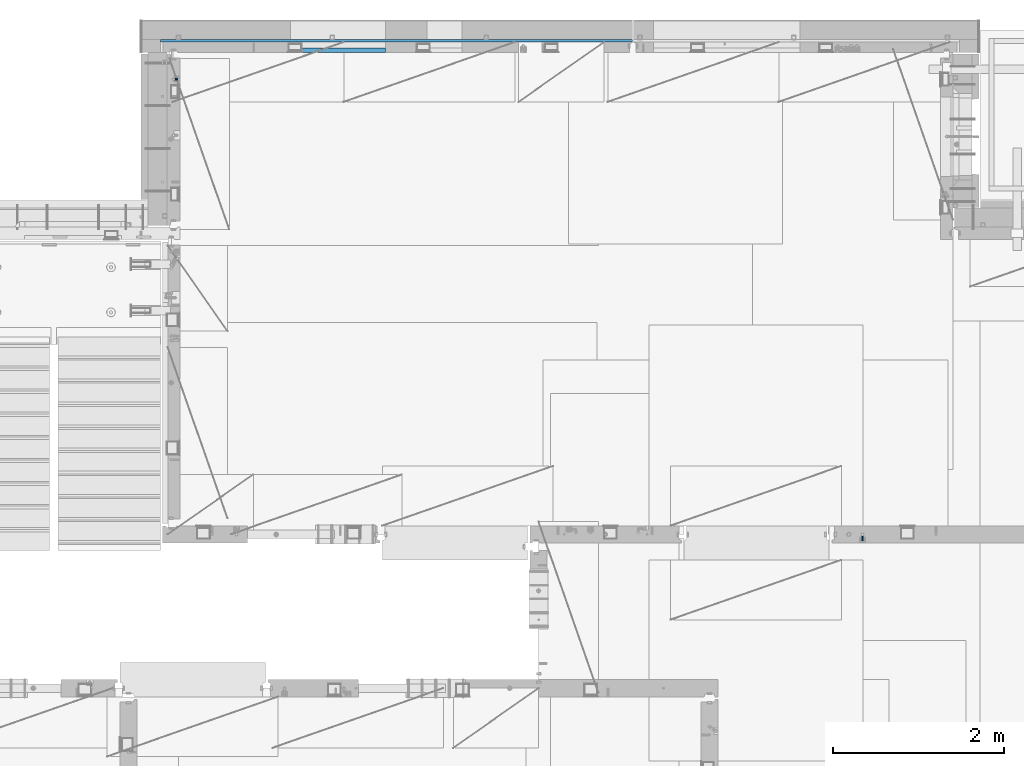
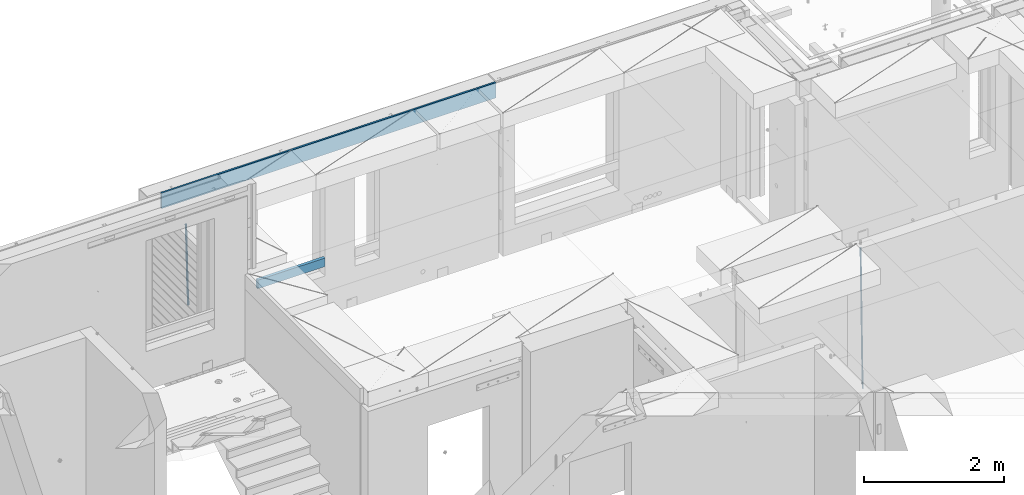
# One storey, part 121 of 341: 4 beams, 3 elements without a shape of their own.
"""IFC2X3 building model written with IfcOpenShell, lengths in millimetres."""

import ifcopenshell
import ifcopenshell.guid

model = None  # the IFC model being written
_history = None  # IfcOwnerHistory: only IFC2X3 demands one
_inside = {}  # id of a spatial element -> (the spatial element, [elements in it])
_under = {}  # id of a project, library or spatial element -> (it, [spatial elements below it])
_declared = {}  # id of a project -> (the project, [libraries it declares])
_typed = {}  # id of a type object -> (the type object, [elements of that type])
_made_of = {}  # id of a material, layer set ... -> (it, [elements and type objects made of it])


def new_model(schema):
    """Start an empty IFC model of exactly this schema.

    Asked for "IFC4X3", IfcOpenShell would pick the latest addendum, in which some entities
    have other attributes; the version numbers below select the first issue.
    IFC2X3 requires an IfcOwnerHistory on every rooted entity: one is made here for all.
    """
    global model, _history
    if schema == "IFC4X3":
        model = ifcopenshell.file(schema_version=(4, 3, 0, 0))
    else:
        model = ifcopenshell.file(schema=schema)
    _inside.clear()
    _under.clear()
    _declared.clear()
    _typed.clear()
    _made_of.clear()
    _history = None
    if model.schema == "IFC2X3":
        org = make("IfcOrganization", Name="unknown")
        user = make(
            "IfcPersonAndOrganization",
            ThePerson=make("IfcPerson", FamilyName="unknown"),
            TheOrganization=org,
        )
        app = make(
            "IfcApplication",
            ApplicationDeveloper=org,
            Version="unknown",
            ApplicationFullName="unknown",
            ApplicationIdentifier="unknown",
        )
        _history = make(
            "IfcOwnerHistory",
            OwningUser=user,
            OwningApplication=app,
            ChangeAction="ADDED",
            CreationDate=0,
        )
    return model


def make(cls, **values):
    """One entity of the class cls with the attributes given. An attribute that is None is left unset."""
    return model.create_entity(
        cls, **{name: value for name, value in values.items() if value is not None}
    )


def rooted(cls, **values):
    """An entity with a GlobalId (a new one), such as an element, a storey or a relation."""
    return make(cls, GlobalId=ifcopenshell.guid.new(), OwnerHistory=_history, **values)


def si_unit(unit_type, name, prefix=None):
    """IfcSIUnit, for example si_unit("LENGTHUNIT", "METRE", prefix="MILLI")."""
    return make("IfcSIUnit", UnitType=unit_type, Prefix=prefix, Name=name)


def assignment(units):
    """IfcUnitAssignment: the units of a project."""
    return None if units is None else make("IfcUnitAssignment", Units=units)


def point(xyz):
    """IfcCartesianPoint."""
    return None if xyz is None else make("IfcCartesianPoint", Coordinates=xyz)


def direction(xyz):
    """IfcDirection."""
    return None if xyz is None else make("IfcDirection", DirectionRatios=xyz)


def frame(location, z_axis=None, x_axis=None):
    """IfcAxis2Placement3D, a coordinate frame: its origin and axes. An axis left out is left unset."""
    return make(
        "IfcAxis2Placement3D",
        Location=point(location),
        Axis=direction(z_axis),
        RefDirection=direction(x_axis),
    )


def origin_with_axes():
    """The frame at (0, 0, 0) with the z axis (0, 0, 1) and the x axis (1, 0, 0) written out."""
    return frame((0.0, 0.0, 0.0), z_axis=(0.0, 0.0, 1.0), x_axis=(1.0, 0.0, 0.0))


def place(relative_to, where):
    """IfcLocalPlacement: puts the frame where relative to a parent placement (None: the world)."""
    return make(
        "IfcLocalPlacement", PlacementRelTo=relative_to, RelativePlacement=where
    )


def context(
    kind, dimensions, precision=None, world=None, true_north=None, identifier=None
):
    """IfcGeometricRepresentationContext, for example the 3D "Model" context."""
    return make(
        "IfcGeometricRepresentationContext",
        ContextIdentifier=identifier,
        ContextType=kind,
        CoordinateSpaceDimension=dimensions,
        Precision=precision,
        WorldCoordinateSystem=world,
        TrueNorth=true_north,
    )


def subcontext(parent, identifier, kind, view, scale=None):
    """IfcGeometricRepresentationSubContext, for example "Body" below "Model"."""
    return make(
        "IfcGeometricRepresentationSubContext",
        ContextIdentifier=identifier,
        ContextType=kind,
        ParentContext=parent,
        TargetScale=scale,
        TargetView=view,
    )


def project(units=None, contexts=None):
    """IfcProject with its units and contexts."""
    return rooted(
        "IfcProject",
        Name="project",
        RepresentationContexts=contexts,
        UnitsInContext=assignment(units),
    )


def spatial(cls, under=None, at=None, **own):
    """A site, building, storey or space (cls), placed at a placement, below another one or the project."""
    s = rooted(cls, ObjectPlacement=at, **own)
    if under is not None:
        _under.setdefault(under.id(), (under, []))[1].append(s)
    return s


def faces_of(points, faces, orient=None, outer=None):
    """IfcFace entities. A face is a list of loops; a loop is a list of indices into points, from 0.

    orient and outer hold one flag for each loop. By default every Orientation is true, the
    first loop of a face is its IfcFaceOuterBound and the others are IfcFaceBound.
    """
    made = []
    for i, loops in enumerate(faces):
        bounds = []
        for j, loop in enumerate(loops):
            is_outer = j == 0 if outer is None else outer[i][j]
            bounds.append(
                make(
                    "IfcFaceOuterBound" if is_outer else "IfcFaceBound",
                    Bound=make("IfcPolyLoop", Polygon=[points[k] for k in loop]),
                    Orientation=True if orient is None else orient[i][j],
                )
            )
        made.append(make("IfcFace", Bounds=bounds))
    return made


def faceted_brep(points, faces, orient=None, outer=None, voids=None):
    """IfcFacetedBrep: a solid bounded by flat faces; with voids (closed shells), ...WithVoids."""
    shared = [point(p) for p in points]
    hull = make("IfcClosedShell", CfsFaces=faces_of(shared, faces, orient, outer))
    if voids is None:
        return make("IfcFacetedBrep", Outer=hull)
    return make(
        "IfcFacetedBrepWithVoids",
        Outer=hull,
        Voids=[
            make(cls, CfsFaces=faces_of(shared, fs, o, b)) for cls, fs, o, b in voids
        ],
    )


def shape(context_of_items, identifier, shape_type, items):
    """IfcShapeRepresentation: the items that make up one representation, for example the "Body"."""
    return make(
        "IfcShapeRepresentation",
        ContextOfItems=context_of_items,
        RepresentationIdentifier=identifier,
        RepresentationType=shape_type,
        Items=items,
    )


def material(Name=None, Category=None):
    """IfcMaterial."""
    return make("IfcMaterial", Name=Name, Category=Category)


def made_of(thing, what):
    """Note that an element or type object is made of a material, layer set ...; save() writes the relation."""
    if what is not None:
        _made_of.setdefault(what.id(), (what, []))[1].append(thing)
    return thing


def type_object(cls, material=None, **own):
    """A type object (cls), such as IfcWallType, which elements share."""
    return made_of(rooted(cls, **own), material)


def element(
    cls,
    number,
    at=None,
    inside=None,
    cuts=None,
    type_object=None,
    material=None,
    context=None,
    identifier="Body",
    shape_type=None,
    held_by="IfcProductDefinitionShape",
    body=None,
    shapes=None,
    **own,
):
    """One element of the class cls, such as IfcWall. Its Tag is "e" and its number.

    at: its placement. inside: the storey or other place that contains it. cuts: it is an
    opening in that element (IfcRelVoidsElement). A single representation is given by context,
    identifier, shape_type and body (its items); several are given by shapes. held_by: the class
    of the entity that holds the representations. save() writes the other relations.
    """
    e = rooted(cls, Tag="e%d" % number, ObjectPlacement=at, **own)
    if body is not None:
        shapes = [shape(context, identifier, shape_type, body)]
    if shapes is not None:
        e.Representation = make(held_by, Representations=shapes)
    if inside is not None:
        _inside.setdefault(inside.id(), (inside, []))[1].append(e)
    if cuts is not None:
        rooted(
            "IfcRelVoidsElement", RelatingBuildingElement=cuts, RelatedOpeningElement=e
        )
    if type_object is not None:
        _typed.setdefault(type_object.id(), (type_object, []))[1].append(e)
    return made_of(e, material)


def aggregate(whole, parts):
    """IfcRelAggregates: a whole, such as a stair, and the parts it consists of."""
    return rooted("IfcRelAggregates", RelatingObject=whole, RelatedObjects=parts)


def save(model, path):
    """Write the relations noted so far, then the file.

    IfcRelAggregates (storeys below a building ...), IfcRelContainedInSpatialStructure (elements
    in a storey), IfcRelDefinesByType, IfcRelAssociatesMaterial and IfcRelDeclares: one each for
    every whole, place, type object, material and project.
    """
    for whole, parts in _under.values():
        aggregate(whole, parts)
    for where, things in _inside.values():
        rooted(
            "IfcRelContainedInSpatialStructure",
            RelatedElements=things,
            RelatingStructure=where,
        )
    for kind, things in _typed.values():
        rooted("IfcRelDefinesByType", RelatedObjects=things, RelatingType=kind)
    for what, things in _made_of.values():
        rooted("IfcRelAssociatesMaterial", RelatedObjects=things, RelatingMaterial=what)
    for by, libraries in _declared.values():
        rooted("IfcRelDeclares", RelatingContext=by, RelatedDefinitions=libraries)
    model.write(path)


model = new_model("IFC2X3")

# Units and contexts
model_context = context("Model", 3, precision=1e-05, world=origin_with_axes())
body_context = subcontext(model_context, "Body", "Model", "MODEL_VIEW")
ifc_project = project(units=[si_unit("LENGTHUNIT", "METRE", prefix="MILLI"), si_unit("AREAUNIT", "SQUARE_METRE"), si_unit("VOLUMEUNIT", "CUBIC_METRE"), si_unit("MASSUNIT", "GRAM", prefix="KILO"), si_unit("TIMEUNIT", "SECOND"), si_unit("PLANEANGLEUNIT", "RADIAN"), si_unit("SOLIDANGLEUNIT", "STERADIAN"), si_unit("THERMODYNAMICTEMPERATUREUNIT", "DEGREE_CELSIUS"), si_unit("LUMINOUSINTENSITYUNIT", "LUMEN")], contexts=[model_context])

# Site, building, storey
site_placement = place(None, origin_with_axes())
site = spatial("IfcSite", under=ifc_project, at=site_placement, CompositionType="ELEMENT")
building_placement = place(site_placement, origin_with_axes())
building = spatial("IfcBuilding", under=site, at=building_placement, CompositionType="ELEMENT")
storey_placement = place(building_placement, origin_with_axes())
storey = spatial("IfcBuildingStorey", under=building, at=storey_placement, Name="5", CompositionType="ELEMENT", Elevation=0.0)

# Assembly, beam
assembly_1_placement = place(storey_placement, origin_with_axes())
assembly_1 = element("IfcElementAssembly", 1, at=assembly_1_placement, inside=storey, AssemblyPlace="NOTDEFINED", PredefinedType="REINFORCEMENT_UNIT")
ifc_material_1 = material()
beam_type_1 = type_object("IfcBeamType", Name="D20", PredefinedType="NOTDEFINED")
beam_1_placement = place(assembly_1_placement, frame((30400.0000000039, 16915.0002418615, 93990.0), z_axis=(-0.000205762999925498, 0.999642804629538, -0.0267249099901004), x_axis=(4.30000201928125e-08, 0.0267249099948059, 0.999642825806181)))
beam_1 = element("IfcBeam", 2, at=beam_1_placement, type_object=beam_type_1, material=ifc_material_1, Name="JM20", ObjectType="D20", context=body_context, shape_type="Brep", body=[
    faceted_brep([(0.0, -10.0, 0.0), (-4.19531716033816e-08, -7.07106781186667, -7.07106781187031), (60.4266690400545, -7.0710677960451, -7.07106780570757), (60.4266690441291, -9.99999998418934, 6.15546014159918e-09), (0.0, 0.0, -10.0), (60.426669036824, 1.58106558956206e-08, -9.99999999384454), (4.196772351861e-08, 7.07106781186303, -7.07106781186667), (60.4266690363438, 7.07106782768096, -7.07106780570757), (0.0, 10.0, 0.0), (60.4266690388904, 10.0000000158179, 6.15182216279209e-09), (4.196772351861e-08, 7.07106781185939, 7.07106781185939), (60.4266690429649, 7.07106782768096, 7.07106781802577), (0.0, 0.0, 10.0), (60.4266690461809, 1.58179318532348e-08, 10.0000000061555), (-4.19531716033816e-08, -7.07106781187031, 7.07106781185939), (60.4266690466611, -7.07106779605238, 7.07106781802213), (61.0378400410118, -7.07106779588503, -7.07106780564936), (60.991799419251, -9.99999998403655, 6.21366780251265e-09), (61.0569027789461, 1.5985278878361e-08, -9.99999999378269), (61.0378209396877, 7.07106782784831, -7.07106780564936), (60.9917724058905, 10.0000000159635, 6.21366780251265e-09), (60.9457317841297, 7.07106782781193, 7.0710678180767), (60.9266690461809, 1.59488990902901e-08, 10.0000000062028), (60.9457508854539, -7.07106779591413, 7.0710678180767), (61.6489592143771, -7.07106614513759, -7.06310863441468), (61.5568818710308, -9.9999984576425, 0.00735959856683621), (61.6870830769039, 1.71821739058942e-06, -9.99179257185824), (61.6489210170112, 7.07106947854481, -7.06310888312146), (61.556827851804, 10.0000015422847, 0.00735924683976918), (61.4647505084577, 7.07106922979438, 7.07782747982128), (61.4266266459163, 1.36643211590126e-06, 10.0065114172685), (61.464788705809, -7.07106639389531, 7.07782772852806), (176.543135720174, -7.07075579406956, -5.56673531796696), (176.451058376813, -9.99968810657447, 1.50373291501455), (176.581259582701, 0.000312069292704109, -8.49541925541052), (176.543097522794, 7.07137982961285, -5.56673556667374), (176.451004357587, 10.00031189336, 1.50373256329476), (176.35892701424, 7.07137958085514, 8.57420079627263), (176.320803151699, 0.000311717507429421, 11.5028847337162), (176.358965211621, -7.07075604281999, 8.57420104497578), (177.098753836006, -7.07075429323595, -5.55949898843028), (176.98362511232, -9.99968666800123, 1.510669025065), (177.146421932586, 0.000313595905026887, -8.48805862247536), (177.098706077581, 7.07138133041735, -5.55949936166144), (176.983557571715, 10.0003133318824, 1.51066849724157), (176.868428848029, 7.07138095712435, 8.58083651073321), (176.820760751449, 0.000313067976094317, 11.5093961447819), (176.868476606425, -7.07075466652896, 8.58083688396073), (177.654312950661, -7.07075204110879, -5.54863964998367), (177.516135294456, -9.99968450931192, 1.52107783331303), (177.711524267797, 0.000315886711177882, -8.47701274570863), (177.654255632195, 7.07138358250813, -5.54864021007961), (177.516054233929, 10.0003154905207, 1.5210770412159), (177.377876577739, 7.0713830223176, 8.59079452451624), (177.320665260588, 0.000315094497636892, 11.5191676202448), (177.377933896176, -7.07075260129932, 8.59079508461218), (299.499456785634, -7.07025810522464, -3.16697112782276), (299.361279129444, -9.99919057342777, 3.90274635547394), (299.556668102785, 0.000809822595329024, -6.09534422354773), (299.499399467197, 7.07187751838501, -3.1669716879187), (299.361198068917, 10.0008094264049, 3.90274556338045), (299.223020412712, 7.07187695819448, 10.9724630466735), (299.165809095575, 0.000809030381788034, 13.9008361423985), (299.223077731163, -7.07025866542244, 10.9724636067695), (300.03174732349, -7.07025594743027, -3.15656661289177), (299.971788958996, -9.99918809853989, 3.91467979818117), (300.056572611924, 0.000811849109595641, -6.08557274808481), (300.031722507032, 7.07187967631762, -3.15656653768019), (299.971753863239, 10.0008119014747, 3.91467990454839), (299.91179549876, 7.07187975035777, 10.9859263156177), (299.886970210311, 0.000811953817901667, 13.9149324508144), (299.911820315203, -7.0702558733974, 10.9859262404061), (300.564137759997, -7.07025623699155, -3.15794273276697), (300.582413367199, -9.99918843065097, 3.91310145956595), (300.556570941641, 0.000811577163403854, -6.0868651410201), (300.564145451674, 7.07187938674906, -3.15794274158179), (300.582424244858, 10.0008115693345, 3.91310144710224), (300.600699852032, 7.07187937566778, 10.9841456394352), (300.608266670402, 0.000811561512819026, 13.9130680476919), (300.600692160384, -7.07025624805829, 10.98414564825), (2294.16589219622, -7.0713405251372, -8.31099358700158), (2294.1841678034, -10.0002727187966, -1.23994939466866), (2294.15832537785, -0.000272710982244462, -11.2399159952547), (2294.16589988787, 7.07079509858886, -8.31099359582004), (2294.18417868105, 9.99972728118883, -1.23994940713601), (2294.20245428824, 7.07079508752213, 5.83109478519327), (2294.2100211066, -0.00027272663282929, 8.76001719345368), (2294.20244659658, -7.07134053620393, 5.83109479401173), (2294.7782683276, -7.07134085819416, -8.31257645345977), (2294.72126025338, -10.000273010919, -1.24133766827799), (2294.84007459224, -0.000273081772320438, -11.2416781768807), (2294.87047377572, 7.07079471537872, -8.31281477453012), (2294.85165844864, 9.9997269181622, -1.24167470516841), (2294.7946503744, 7.07079476544459, 5.82956408001337), (2294.73284410976, -0.000273010977252852, 8.75866580342336), (2294.7024449263, -7.07134080815013, 5.82980240107645), (2295.39054023061, -7.0793250091956, -8.30442771922026), (2295.25826128852, -10.0072756143927, -1.23419071494573), (2295.52170777075, -0.00916171800054144, -11.2326063125765), (2295.57492774284, 7.06160849139269, -8.30343918807193), (2295.51902460904, 9.99102432676591, -1.23279272078435), (2295.38674566693, 7.06307372157607, 5.83744428349019), (2295.25557812679, -0.0070895696117077, 8.76562287684646), (2295.20235815471, -7.07785977901949, 5.83645575234186), (2317.1947101649, -7.36365585014573, -8.01423575520312), (2317.06243122277, -10.2916064553428, -0.94399875092131), (2317.32587770502, -0.293492558957951, -10.9424143485521), (2317.37909767711, 6.77727765044983, -8.01324722405116), (2317.32319454331, 9.70669348581578, -0.942600756767206), (2317.1909156012, 6.77874288063322, 6.12763624751096), (2317.05974806109, -0.291420410569117, 9.0558148408636), (2317.00652808898, -7.36219061996962, 6.12664771636264), (2317.83015404257, -7.37194216843636, -8.00577862486898), (2317.72252095213, -10.300214160583, -0.935213608652703), (2317.90419832576, -0.301033978277701, -10.9347174723516), (2317.90127966482, 6.77046829039318, -8.00629749759901), (2317.82310777172, 9.70017451494641, -0.935947405505431), (2317.71547468127, 6.77190252279979, 6.13461761071085), (2317.64143039809, -0.29900566735887, 9.06355645819713), (2317.64434905903, -7.37050793602975, 6.13513648344451), (2318.46565174212, -7.3700661537805, -7.99751648408346), (2318.38266643914, -10.2982456018653, -0.926623872735945), (2318.48256818345, -0.299336209594912, -10.9272153854981), (2318.42350634121, 6.77200652527245, -7.99954269419686), (2318.32306384158, 9.70166538090416, -0.929489366557391), (2318.2400785386, 6.77348593281204, 6.14140324480104), (2318.22316209726, -0.297244011366274, 9.07110214621207), (2318.2822239395, -7.36858674623363, 6.1434294549108), (2418.48643733139, -7.07180401323421, -6.70013846199799), (2418.4034520284, -9.99998346132634, 0.370754149349523), (2418.5033537727, -0.00107406904135132, -9.62983736341266), (2418.44429193046, 7.07026866581873, -6.70216467211139), (2418.34384943081, 9.99992752145772, 0.367888655531715), (2418.26086412782, 7.0717480733656, 7.43878126688651), (2418.24394768651, 0.00101812917273492, 10.3684801682975), (2418.30300952874, -7.07032460568735, 7.44080747699627)], [[[0, 1, 2, 3]], [[1, 4, 5, 2]], [[4, 6, 7, 5]], [[6, 8, 9, 7]], [[8, 10, 11, 9]], [[10, 12, 13, 11]], [[12, 14, 15, 13]], [[14, 0, 3, 15]], [[14, 12, 10, 8, 6, 4, 1, 0]], [[3, 2, 16, 17]], [[2, 5, 18, 16]], [[5, 7, 19, 18]], [[7, 9, 20, 19]], [[9, 11, 21, 20]], [[11, 13, 22, 21]], [[13, 15, 23, 22]], [[15, 3, 17, 23]], [[17, 16, 24, 25]], [[16, 18, 26, 24]], [[18, 19, 27, 26]], [[19, 20, 28, 27]], [[20, 21, 29, 28]], [[21, 22, 30, 29]], [[22, 23, 31, 30]], [[23, 17, 25, 31]], [[25, 24, 32, 33]], [[24, 26, 34, 32]], [[26, 27, 35, 34]], [[27, 28, 36, 35]], [[28, 29, 37, 36]], [[29, 30, 38, 37]], [[30, 31, 39, 38]], [[31, 25, 33, 39]], [[33, 32, 40, 41]], [[32, 34, 42, 40]], [[34, 35, 43, 42]], [[35, 36, 44, 43]], [[36, 37, 45, 44]], [[37, 38, 46, 45]], [[38, 39, 47, 46]], [[39, 33, 41, 47]], [[41, 40, 48, 49]], [[40, 42, 50, 48]], [[42, 43, 51, 50]], [[43, 44, 52, 51]], [[44, 45, 53, 52]], [[45, 46, 54, 53]], [[46, 47, 55, 54]], [[47, 41, 49, 55]], [[49, 48, 56, 57]], [[48, 50, 58, 56]], [[50, 51, 59, 58]], [[51, 52, 60, 59]], [[52, 53, 61, 60]], [[53, 54, 62, 61]], [[54, 55, 63, 62]], [[55, 49, 57, 63]], [[57, 56, 64, 65]], [[56, 58, 66, 64]], [[58, 59, 67, 66]], [[59, 60, 68, 67]], [[60, 61, 69, 68]], [[61, 62, 70, 69]], [[62, 63, 71, 70]], [[63, 57, 65, 71]], [[65, 64, 72, 73]], [[64, 66, 74, 72]], [[66, 67, 75, 74]], [[67, 68, 76, 75]], [[68, 69, 77, 76]], [[69, 70, 78, 77]], [[70, 71, 79, 78]], [[71, 65, 73, 79]], [[73, 72, 80, 81]], [[72, 74, 82, 80]], [[74, 75, 83, 82]], [[75, 76, 84, 83]], [[76, 77, 85, 84]], [[77, 78, 86, 85]], [[78, 79, 87, 86]], [[79, 73, 81, 87]], [[81, 80, 88, 89]], [[80, 82, 90, 88]], [[82, 83, 91, 90]], [[83, 84, 92, 91]], [[84, 85, 93, 92]], [[85, 86, 94, 93]], [[86, 87, 95, 94]], [[87, 81, 89, 95]], [[89, 88, 96, 97]], [[88, 90, 98, 96]], [[90, 91, 99, 98]], [[91, 92, 100, 99]], [[92, 93, 101, 100]], [[93, 94, 102, 101]], [[94, 95, 103, 102]], [[95, 89, 97, 103]], [[97, 96, 104, 105]], [[96, 98, 106, 104]], [[98, 99, 107, 106]], [[99, 100, 108, 107]], [[100, 101, 109, 108]], [[101, 102, 110, 109]], [[102, 103, 111, 110]], [[103, 97, 105, 111]], [[105, 104, 112, 113]], [[104, 106, 114, 112]], [[106, 107, 115, 114]], [[107, 108, 116, 115]], [[108, 109, 117, 116]], [[109, 110, 118, 117]], [[110, 111, 119, 118]], [[111, 105, 113, 119]], [[113, 112, 120, 121]], [[112, 114, 122, 120]], [[114, 115, 123, 122]], [[115, 116, 124, 123]], [[116, 117, 125, 124]], [[117, 118, 126, 125]], [[118, 119, 127, 126]], [[119, 113, 121, 127]], [[121, 120, 128, 129]], [[120, 122, 130, 128]], [[122, 123, 131, 130]], [[123, 124, 132, 131]], [[124, 125, 133, 132]], [[125, 126, 134, 133]], [[126, 127, 135, 134]], [[127, 121, 129, 135]], [[130, 131, 132, 133, 134, 135, 129, 128]]]),
])
aggregate(assembly_1, [beam_1])

assembly_2_placement = place(storey_placement, origin_with_axes())
assembly_2 = element("IfcElementAssembly", 3, at=assembly_2_placement, inside=storey, AssemblyPlace="NOTDEFINED", PredefinedType="REINFORCEMENT_UNIT")
beam_type_2 = type_object("IfcBeamType", Name="D25", PredefinedType="NOTDEFINED")
beam_2_placement = place(assembly_2_placement, frame((22375.0000022791, 22307.0000022831, 94990.0), z_axis=(-0.999642804636942, -0.000205726999925762, -0.0267249099902983), x_axis=(-0.0267249099948371, 4.30000201934385e-08, 0.999642825806181)))
beam_2 = element("IfcBeam", 4, at=beam_2_placement, type_object=beam_type_2, material=ifc_material_1, Name="JM25", ObjectType="D25", context=body_context, shape_type="Brep", body=[
    faceted_brep([(-7.41420080885291e-08, -12.5, -3.63797880709171e-12), (-6.42030499875546e-08, -10.8253175473074, -6.25000000000364), (60.4103898235917, -10.8253175318459, -6.2499999938409), (60.4103898269532, -12.4999999845422, 6.16273609921336e-09), (-3.70782800018787e-08, -6.25000000000364, -10.8253175473074), (60.4103898202884, -6.24999998454587, -10.8253175411446), (-1.45519152283669e-11, -3.63797880709171e-12, -12.5), (60.4103898179019, 1.54577719513327e-08, -12.4999999938373), (3.70637280866504e-08, 6.25, -10.8253175473074), (60.410389817087, 6.25000001545777, -10.825317541141), (6.42030499875546e-08, 10.8253175473001, -6.25000000000364), (60.410389818062, 10.8253175627578, -6.24999999383726), (7.41420080885291e-08, 12.4999999999927, 0.0), (60.4103898205503, 12.5000000154541, 6.16273609921336e-09), (6.42176019027829e-08, 10.8253175473001, 6.24999999999636), (60.4103898238973, 10.8253175627651, 6.2500000061591), (3.70928319171071e-08, 6.24999999999636, 10.8253175473037), (60.4103898272151, 6.25000001546141, 10.8253175534664), (1.45519152283669e-11, -3.63797880709171e-12, 12.4999999999964), (60.4103898296162, 1.54541339725256e-08, 12.5000000061591), (-3.7049176171422e-08, -6.25000000000364, 10.8253175473001), (60.4103898304165, -6.24999998454587, 10.8253175534701), (-6.41884980723262e-08, -10.8253175473074, 6.25), (60.4103898294561, -10.8253175318459, 6.25000000616637), (61.0324985728803, -10.8253175316895, -6.24999999377542), (60.991802792938, -12.4999999843931, 6.22458173893392e-09), (61.0622854283865, -6.24999998437852, -10.8253175410755), (61.0731819955545, 1.5628756955266e-08, -12.4999999937718), (61.0622685480339, 6.25000001562512, -10.8253175410791), (61.032469335245, 10.8253175629216, -6.24999999377178), (60.9917690322181, 12.5000000156033, 6.22458173893392e-09), (60.9510732522613, 10.8253175629034, 6.25000000621731), (60.9212863967696, 6.25000001558874, 10.8253175535247), (60.9103898296162, 1.55814632307738e-08, 12.5000000062137), (60.9213032771368, -6.24999998441126, 10.8253175535174), (60.9511024898966, -10.8253175317113, 6.25000000621731), (61.6545545670233, -10.8253158516927, -6.24189838219536), (61.573166454793, -12.499998414296, 0.00757164385504439), (61.7141257553885, -6.24999822394238, -10.8168280205282), (61.7359179680789, 1.80548886419274e-06, -12.491368569139), (61.7140919992817, 6.25000177601396, -10.8168282403167), (61.6544960997562, 10.8253192428383, -6.2418987628771), (61.5730989426083, 12.5000015856094, 0.0075712042817031), (61.4917108303925, 10.8253190230062, 6.25704123032847), (61.4321396420273, 6.25000139525582, 10.8319708686649), (61.4103474293224, 1.36582457344048e-06, 12.5065114172721), (61.4321733981196, -6.24999860470052, 10.8319710884571), (61.4917692976451, -10.8253160715249, 6.25704161101385), (176.524302641745, -10.8250056210964, -4.74584321979273), (176.442914529529, -12.4996881836996, 1.50362680625403), (176.583873830095, -6.24968799334965, -9.3207728581292), (176.605666042786, 0.000312036081595579, -10.9953134067364), (176.583840074018, 6.25031200660669, -9.32077307791769), (176.524244174492, 10.8256294734347, -4.74584360047811), (176.44284701733, 12.5003118162058, 1.50362636668069), (176.361458905099, 10.8256292535989, 7.75309639272746), (176.301887716749, 6.25031162585219, 12.3280260310676), (176.280095504058, 0.000311596420942806, 14.0025665796711), (176.301921472827, -6.24968837410415, 12.3280262508561), (176.361517372367, -10.8250058409321, 7.75309677341284), (177.085397012124, -10.8250041057399, -4.73853556792164), (176.983633547483, -12.4996867233749, 1.51066909103247), (177.159881729676, -6.24968643771717, -9.31327097355097), (177.187129580227, 0.000313606451527448, -10.987740468332), (177.159839524218, 6.25031356221734, -9.31327130338468), (177.085323910098, 10.8256309887511, -4.73853613920801), (176.983549136537, 12.5003132764905, 1.51066843136869), (176.881785671867, 10.8256306588555, 7.7598730903228), (176.80730095433, 6.25031299082912, 12.3346084959521), (176.780053103794, 0.000312946667690994, 14.0090779907332), (176.807343159802, -6.2496870091054, 12.3346088257895), (176.881858773908, -10.8250044356355, 7.7598736616128), (177.646431799818, -10.8250018318176, -4.72756919822132), (177.524295146417, -12.4996845320202, 1.52123723245313), (177.735828462886, -6.24968410334986, -9.30201312475765), (177.768531371941, 0.00031596292683389, -10.9763759912421), (177.735777808921, 6.25031589654827, -9.30201361973741), (177.646344064575, 10.8256332626152, -4.72757005553649), (177.524193838486, 12.5003154677688, 1.52123624250817), (177.402057185071, 10.8256327675663, 7.77004267317898), (177.312660521988, 6.2503150390985, 12.3444865997226), (177.279957612933, 0.00031497282179771, 14.0188494661961), (177.312711175953, -6.24968496079964, 12.3444870946951), (177.402144920314, -10.8250023268702, 7.77004353049415), (299.450416306776, -10.8245081491878, -2.34670520440704), (299.32827965336, -12.4991908493976, 3.9021012262674), (299.539812969844, -6.24919042071997, -6.92114913095065), (299.572515878914, 0.000809645553090377, -8.59551199742418), (299.539762315893, 6.25080957917817, -6.9211496259195), (299.450328571547, 10.8261269452451, -2.34670606172585), (299.328178345429, 12.5008091504023, 3.9021002363188), (299.206041692043, 10.8261264501925, 10.1509066669969), (299.11664502896, 6.25080872172475, 14.7253505935405), (299.083942119891, 0.000808655455330154, 16.3997134600104), (299.116695682911, -6.24919127817338, 14.7253510885093), (299.206129427272, -10.8245086442366, 10.1509075243121), (300.022114107283, -10.8245058320463, -2.33553040816332), (299.97179243555, -12.4991882411778, 3.91467976726199), (300.058946494231, -6.24918831662217, -6.9110017919993), (300.072420388053, 0.000811671710835071, -8.58574052196127), (300.058925469799, 6.25081168339239, -6.91100170781283), (300.022077691901, 10.8261292625939, -2.33553026234586), (299.971750386685, 12.5008117588586, 3.91467993563856), (299.921428714966, 10.8261293497235, 10.1648901110639), (299.884596327989, 6.25081183430666, 14.7403614948998), (299.871122434168, 0.000811845966381952, 16.4151002248582), (299.884617352436, -6.24918816571881, 14.7403614107134), (299.921465130334, -10.8245057449167, 10.1648899652428), (300.593917726728, -10.8245062259339, -2.33749813354007), (300.615424329342, -12.4991886845492, 3.91246486206001), (300.578176108116, -6.24918867429733, -6.91278859651356), (300.572417427509, 0.00081132728519151, -8.58746114217138), (300.578184718717, 6.25081132569903, -6.91278861431056), (300.59393264071, 10.8261288686736, -2.33749816436102), (300.615441550515, 12.5008113154472, 3.91246482646966), (300.636948153115, 10.8261288568356, 10.1624278220661), (300.652689771727, 6.25081130520266, 14.7377182850432), (300.658448452334, 0.000811303612863412, 16.4123908306974), (300.65268116114, -6.24918869479734, 14.7377183028366), (300.636933239148, -10.8245062377719, 10.162427852887), (1293.8225958722, -10.8251904135213, -5.7554570479515), (1293.84410247482, -12.4998728721366, 0.494505947652215), (1293.80685425361, -6.2498728618848, -10.330747510925), (1293.801095573, 0.000127139694086509, -12.0054200565755), (1293.80686286419, 6.25012713810793, -10.3307475287183), (1293.82261078618, 10.8254446810788, -5.75545707877609), (1293.84411969599, 12.5001271278561, 0.49450591205823), (1293.86562629859, 10.8254446692445, 6.7444689076583), (1293.8813679172, 6.25012711760428, 11.3197593706318), (1293.88712659782, 0.00012711602539639, 12.994431916286), (1293.88135930662, -6.24987288238844, 11.3197593884252), (1293.86561138462, -10.8251904253593, 6.7444689384829), (1294.43576264779, -10.8251908359052, -5.75756711474241), (1294.39401066334, -12.4998732509448, 0.492613570157118), (1294.4881651176, -6.24987333120953, -10.3330920792978), (1294.53717687333, 0.000126632643514313, -12.0079531043048), (1294.56966525462, 6.25012661264918, -10.3333725306838), (1294.5769250259, 10.8254441614699, -5.75805287079493), (1294.55701093735, 12.5001266367835, 0.492052667374082), (1294.51525895292, 10.825444221744, 6.74223335227362), (1294.46285648308, 6.25012671704826, 11.3177583168253), (1294.41384472734, 0.000126753191580065, 12.9926193418323), (1294.38135634607, -6.24987322681045, 11.318038768215), (1294.37409657479, -10.8251907756348, 6.74271910832613), (1295.04882664244, -10.8331853159034, -5.74940783883358), (1294.94382667454, -12.5070429642874, 0.499931077909423), (1295.16936177819, -6.25875627512141, -10.3240260249331), (1295.27313478947, -0.00947040924438625, -11.9981582317523), (1295.33233978174, 6.24018118068125, -10.3232220864411), (1295.33111282514, 10.8156093981706, -5.74801537651729), (1295.26978268167, 12.4908319473179, 0.501538954897114), (1295.16478271378, 10.8169742989339, 6.75087787164011), (1295.04424757806, 6.24254525814467, 11.3254960577397), (1294.94047456676, -0.00674060772507801, 12.9996282645552), (1294.88126957447, -6.25639219765071, 11.3246921192476), (1294.88249653111, -10.8318204151437, 6.74948540932019), (1316.80386422646, -11.116875459662, -5.45986978806832), (1316.69886425855, -12.790733108046, 0.789469128674682), (1316.92439936219, -6.54244641887635, -10.0344879741715), (1317.02817237348, -0.293160553006601, -11.7086201809871), (1317.08737736575, 5.95649103692267, -10.0336840356795), (1317.08615040916, 10.5319192544084, -5.45847732575203), (1317.02482026568, 12.2071418035557, 0.791077005658735), (1316.91982029779, 10.5332841551717, 7.0404159223981), (1316.79928516207, 5.9588551143861, 11.6150341085013), (1316.69551215076, -0.290430751483655, 13.2891663153168), (1316.63630715849, -6.54008234141656, 11.6142301700129), (1316.6375341151, -11.1155105589023, 7.03902346008545), (1317.48953548315, -11.1258167532178, -5.45074418126023), (1317.39899812841, -12.7998629970425, 0.798787218573125), (1317.57265877169, -6.55089985429368, -10.0258602820722), (1317.62609517592, -0.300957588759047, -11.7006624193855), (1317.63552645453, 5.94934306058713, -10.0263887130131), (1317.59842550401, 10.5252390823007, -5.4516594505003), (1317.52473349411, 12.2006228327155, 0.79773035668768), (1317.43419613934, 10.5265765888907, 7.0472617565174), (1317.35107285083, 5.95165968996662, 11.6223778573367), (1317.2976364466, -0.29828257556801, 13.2971799946463), (1317.28820516799, -6.54858322491418, 11.6229062882776), (1317.32530611851, -11.1244792466277, 7.04817702575747), (1318.17526469367, -11.1237887330935, -5.44182040245869), (1318.09919107273, -12.797775016028, 0.807903115066438), (1318.22097315147, -6.5489957269856, -10.0174341323618), (1318.22406890181, -0.299208089221793, -11.6929060708244), (1318.18372244084, 5.95094862978294, -10.0192948650074), (1318.11074457024, 10.526749984605, -5.44504328594121), (1318.02468965146, 12.2021136975018, 0.804181649778911), (1317.94861603052, 10.52812741456, 7.05390516730768), (1317.90290757272, 5.95333440845207, 11.6295188972072), (1317.8998118224, -0.296453229308099, 13.3049908356734), (1317.94015828335, -6.54660994831283, 11.6313796298491), (1318.01313615397, -11.1224113031385, 7.0571280507902), (1418.17602640855, -10.8255863639497, -4.14470589025586), (1418.09995278763, -12.4995726468842, 2.10501762727654), (1418.22173486637, -6.25079335783812, -8.72031962014808), (1418.2248306167, -0.00100572007431765, -10.3957915586216), (1418.18448415573, 6.24915099893042, -8.72218035279366), (1418.11150628512, 10.8249523537488, -4.14792877373111), (1418.02545136634, 12.500316066642, 2.10129616199265), (1417.94937774542, 10.8263297837075, 8.35101967951414), (1417.90366928761, 6.2515367775959, 12.9266334094173), (1417.90057353729, 0.00174913983573788, 14.6021053478798), (1417.94091999825, -6.248407579169, 12.9284941420592), (1418.01389786886, -10.824208933991, 8.35424256299666)], [[[0, 1, 2, 3]], [[1, 4, 5, 2]], [[4, 6, 7, 5]], [[6, 8, 9, 7]], [[8, 10, 11, 9]], [[10, 12, 13, 11]], [[12, 14, 15, 13]], [[14, 16, 17, 15]], [[16, 18, 19, 17]], [[18, 20, 21, 19]], [[20, 22, 23, 21]], [[22, 0, 3, 23]], [[22, 20, 18, 16, 14, 12, 10, 8, 6, 4, 1, 0]], [[3, 2, 24, 25]], [[2, 5, 26, 24]], [[5, 7, 27, 26]], [[7, 9, 28, 27]], [[9, 11, 29, 28]], [[11, 13, 30, 29]], [[13, 15, 31, 30]], [[15, 17, 32, 31]], [[17, 19, 33, 32]], [[19, 21, 34, 33]], [[21, 23, 35, 34]], [[23, 3, 25, 35]], [[25, 24, 36, 37]], [[24, 26, 38, 36]], [[26, 27, 39, 38]], [[27, 28, 40, 39]], [[28, 29, 41, 40]], [[29, 30, 42, 41]], [[30, 31, 43, 42]], [[31, 32, 44, 43]], [[32, 33, 45, 44]], [[33, 34, 46, 45]], [[34, 35, 47, 46]], [[35, 25, 37, 47]], [[37, 36, 48, 49]], [[36, 38, 50, 48]], [[38, 39, 51, 50]], [[39, 40, 52, 51]], [[40, 41, 53, 52]], [[41, 42, 54, 53]], [[42, 43, 55, 54]], [[43, 44, 56, 55]], [[44, 45, 57, 56]], [[45, 46, 58, 57]], [[46, 47, 59, 58]], [[47, 37, 49, 59]], [[49, 48, 60, 61]], [[48, 50, 62, 60]], [[50, 51, 63, 62]], [[51, 52, 64, 63]], [[52, 53, 65, 64]], [[53, 54, 66, 65]], [[54, 55, 67, 66]], [[55, 56, 68, 67]], [[56, 57, 69, 68]], [[57, 58, 70, 69]], [[58, 59, 71, 70]], [[59, 49, 61, 71]], [[61, 60, 72, 73]], [[60, 62, 74, 72]], [[62, 63, 75, 74]], [[63, 64, 76, 75]], [[64, 65, 77, 76]], [[65, 66, 78, 77]], [[66, 67, 79, 78]], [[67, 68, 80, 79]], [[68, 69, 81, 80]], [[69, 70, 82, 81]], [[70, 71, 83, 82]], [[71, 61, 73, 83]], [[73, 72, 84, 85]], [[72, 74, 86, 84]], [[74, 75, 87, 86]], [[75, 76, 88, 87]], [[76, 77, 89, 88]], [[77, 78, 90, 89]], [[78, 79, 91, 90]], [[79, 80, 92, 91]], [[80, 81, 93, 92]], [[81, 82, 94, 93]], [[82, 83, 95, 94]], [[83, 73, 85, 95]], [[85, 84, 96, 97]], [[84, 86, 98, 96]], [[86, 87, 99, 98]], [[87, 88, 100, 99]], [[88, 89, 101, 100]], [[89, 90, 102, 101]], [[90, 91, 103, 102]], [[91, 92, 104, 103]], [[92, 93, 105, 104]], [[93, 94, 106, 105]], [[94, 95, 107, 106]], [[95, 85, 97, 107]], [[97, 96, 108, 109]], [[96, 98, 110, 108]], [[98, 99, 111, 110]], [[99, 100, 112, 111]], [[100, 101, 113, 112]], [[101, 102, 114, 113]], [[102, 103, 115, 114]], [[103, 104, 116, 115]], [[104, 105, 117, 116]], [[105, 106, 118, 117]], [[106, 107, 119, 118]], [[107, 97, 109, 119]], [[109, 108, 120, 121]], [[108, 110, 122, 120]], [[110, 111, 123, 122]], [[111, 112, 124, 123]], [[112, 113, 125, 124]], [[113, 114, 126, 125]], [[114, 115, 127, 126]], [[115, 116, 128, 127]], [[116, 117, 129, 128]], [[117, 118, 130, 129]], [[118, 119, 131, 130]], [[119, 109, 121, 131]], [[121, 120, 132, 133]], [[120, 122, 134, 132]], [[122, 123, 135, 134]], [[123, 124, 136, 135]], [[124, 125, 137, 136]], [[125, 126, 138, 137]], [[126, 127, 139, 138]], [[127, 128, 140, 139]], [[128, 129, 141, 140]], [[129, 130, 142, 141]], [[130, 131, 143, 142]], [[131, 121, 133, 143]], [[133, 132, 144, 145]], [[132, 134, 146, 144]], [[134, 135, 147, 146]], [[135, 136, 148, 147]], [[136, 137, 149, 148]], [[137, 138, 150, 149]], [[138, 139, 151, 150]], [[139, 140, 152, 151]], [[140, 141, 153, 152]], [[141, 142, 154, 153]], [[142, 143, 155, 154]], [[143, 133, 145, 155]], [[145, 144, 156, 157]], [[144, 146, 158, 156]], [[146, 147, 159, 158]], [[147, 148, 160, 159]], [[148, 149, 161, 160]], [[149, 150, 162, 161]], [[150, 151, 163, 162]], [[151, 152, 164, 163]], [[152, 153, 165, 164]], [[153, 154, 166, 165]], [[154, 155, 167, 166]], [[155, 145, 157, 167]], [[157, 156, 168, 169]], [[156, 158, 170, 168]], [[158, 159, 171, 170]], [[159, 160, 172, 171]], [[160, 161, 173, 172]], [[161, 162, 174, 173]], [[162, 163, 175, 174]], [[163, 164, 176, 175]], [[164, 165, 177, 176]], [[165, 166, 178, 177]], [[166, 167, 179, 178]], [[167, 157, 169, 179]], [[169, 168, 180, 181]], [[168, 170, 182, 180]], [[170, 171, 183, 182]], [[171, 172, 184, 183]], [[172, 173, 185, 184]], [[173, 174, 186, 185]], [[174, 175, 187, 186]], [[175, 176, 188, 187]], [[176, 177, 189, 188]], [[177, 178, 190, 189]], [[178, 179, 191, 190]], [[179, 169, 181, 191]], [[181, 180, 192, 193]], [[180, 182, 194, 192]], [[182, 183, 195, 194]], [[183, 184, 196, 195]], [[184, 185, 197, 196]], [[185, 186, 198, 197]], [[186, 187, 199, 198]], [[187, 188, 200, 199]], [[188, 189, 201, 200]], [[189, 190, 202, 201]], [[190, 191, 203, 202]], [[191, 181, 193, 203]], [[194, 195, 196, 197, 198, 199, 200, 201, 202, 203, 193, 192]]]),
])
aggregate(assembly_2, [beam_2])

# Assembly, beams
assembly_3_placement = place(storey_placement, origin_with_axes())
assembly_3 = element("IfcElementAssembly", 5, at=assembly_3_placement, inside=storey, AssemblyPlace="NOTDEFINED", PredefinedType="REINFORCEMENT_UNIT")
ifc_material_2 = material(Name="TIMBER/T24")
beam_type_3 = type_object("IfcBeamType", PredefinedType="NOTDEFINED")
beam_3_placement = place(assembly_3_placement, frame((24815.0002989914, 22644.9998418812, 94685.0), z_axis=(0.0, 0.0, 1.0), x_axis=(-1.0, 3.00000001838171e-08, 0.0)))
beam_3 = element("IfcBeam", 6, at=beam_3_placement, type_object=beam_type_3, material=ifc_material_2, context=body_context, shape_type="Brep", body=[
    faceted_brep([(-3.63797880709171e-12, 24.9999999999964, -75.0), (-3.63797880709171e-12, 24.9999999999964, 75.0), (1110.0, 24.9999999999964, 75.0), (1110.0, 24.9999999999964, -75.0), (0.0, -25.0000000000073, 75.0), (1110.0, -25.0000000000073, 75.0), (0.0, -25.0000000000073, -75.0), (1110.0, -25.0000000000073, -75.0)], [[[0, 1, 2, 3]], [[1, 4, 5, 2]], [[4, 6, 7, 5]], [[6, 0, 3, 7]], [[5, 7, 3, 2]], [[6, 4, 1, 0]]]),
])
ifc_material_3 = material(Name="CONCRETE/C25/30")
beam_type_4 = type_object("IfcBeamType", Name="270X30", PredefinedType="NOTDEFINED")
beam_4_placement = place(assembly_3_placement, frame((27705.0, 22755.0, 96605.0), z_axis=(0.0, 0.0, 1.0), x_axis=(-1.0, 3.00000001838171e-08, 0.0)))
beam_4 = element("IfcBeam", 7, at=beam_4_placement, type_object=beam_type_4, material=ifc_material_3, ObjectType="270X30", context=body_context, shape_type="Brep", body=[
    faceted_brep([(0.0, 15.0, -135.0), (0.0, 15.0, 135.0), (5520.00000000003, 15.0, 135.0), (5520.00000000003, 15.0, -135.0), (0.0, -15.0, 135.0), (5520.00000000003, -15.0, 135.0), (0.0, -15.0, -135.0), (5520.00000000003, -15.0, -135.0)], [[[0, 1, 2, 3]], [[1, 4, 5, 2]], [[4, 6, 7, 5]], [[6, 0, 3, 7]], [[5, 7, 3, 2]], [[6, 4, 1, 0]]]),
])
aggregate(assembly_3, [beam_3, beam_4])

save(model, "model.ifc")
